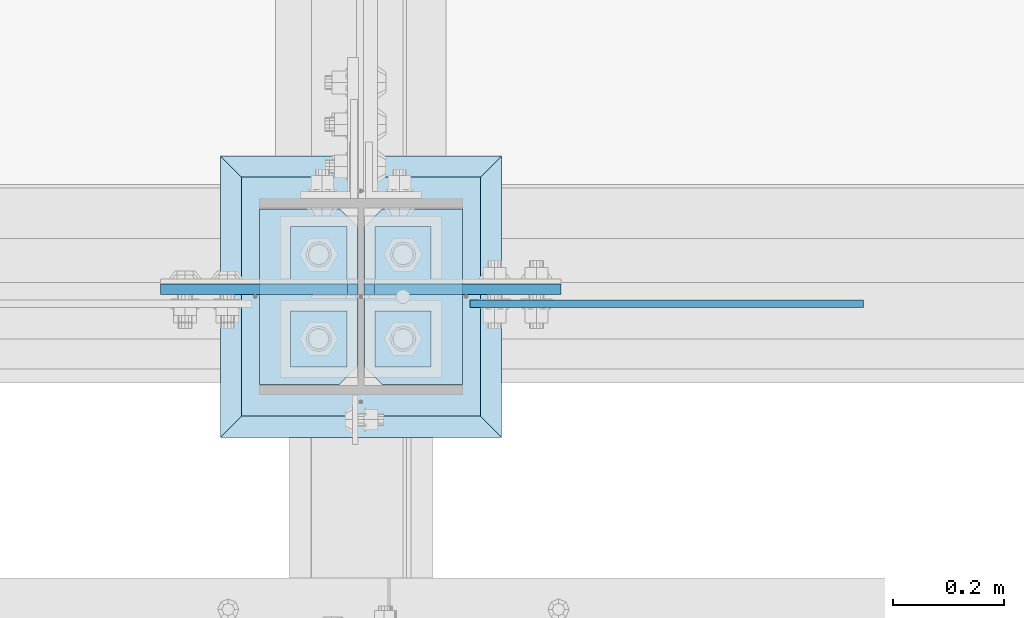
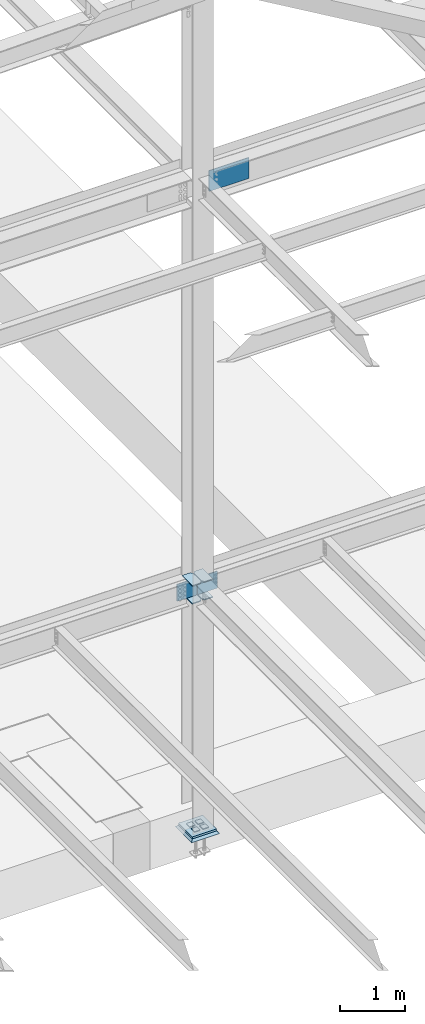
# One storey, part 3190 of 3843: 13 plates, 4 elements without a shape of their own.
"""IFC2X3 building model written with IfcOpenShell, lengths in millimetres."""

from ifc_helpers import new_model, si_unit, frame, origin_with_axes, place, context, subcontext, project, spatial, faceted_brep, material, type_object, element, aggregate, save


model = new_model("IFC2X3")

# Units and contexts
model_context = context("Model", 3, precision=1e-05, world=origin_with_axes())
body_context = subcontext(model_context, "Body", "Model", "MODEL_VIEW")
ifc_project = project(units=[si_unit("LENGTHUNIT", "METRE", prefix="MILLI"), si_unit("AREAUNIT", "SQUARE_METRE"), si_unit("VOLUMEUNIT", "CUBIC_METRE"), si_unit("MASSUNIT", "GRAM", prefix="KILO"), si_unit("TIMEUNIT", "SECOND"), si_unit("PLANEANGLEUNIT", "RADIAN"), si_unit("SOLIDANGLEUNIT", "STERADIAN"), si_unit("THERMODYNAMICTEMPERATUREUNIT", "DEGREE_CELSIUS"), si_unit("LUMINOUSINTENSITYUNIT", "LUMEN")], contexts=[model_context])

# Site, building, storey
site_placement = place(None, origin_with_axes())
site = spatial("IfcSite", under=ifc_project, at=site_placement, CompositionType="ELEMENT")
building_placement = place(site_placement, origin_with_axes())
building = spatial("IfcBuilding", under=site, at=building_placement, Name="Undefined", CompositionType="ELEMENT")
storey_placement = place(building_placement, origin_with_axes())
storey = spatial("IfcBuildingStorey", under=building, at=storey_placement, Name="Undefined", CompositionType="ELEMENT", Elevation=0.0)

# Assembly, plates
assembly_1_placement = place(storey_placement, origin_with_axes())
assembly_1 = element("IfcElementAssembly", 1, at=assembly_1_placement, inside=storey, Name="COLUMN", AssemblyPlace="NOTDEFINED", PredefinedType="RIGID_FRAME")
ifc_material_1 = material(Name="STEEL/A572-50")
plate_type_1 = type_object("IfcPlateType", PredefinedType="NOTDEFINED")
plate_1_placement = place(assembly_1_placement, frame((70439.75625, 25457.15, 34451.925), z_axis=(0.0, 1.0, 0.0), x_axis=(-1.0, 0.0, 0.0)))
plate_1 = element("IfcPlate", 2, at=plate_1_placement, type_object=plate_type_1, material=ifc_material_1, Name="PLATE", context=body_context, shape_type="Brep", body=[
    faceted_brep([(0.0, -9.52500000000146, 0.0), (0.0, -9.52500000000146, 317.5), (0.0, 9.52500000000146, 317.5), (0.0, 9.52500000000146, 0.0), (144.462501525879, -9.52500000000146, 317.5), (144.462501525879, 9.52500000000146, 317.5), (177.800003051758, -9.52500000000146, 284.162498474121), (177.800003051758, 9.52500000000146, 284.162498474121), (177.800003051758, -9.52500000000146, 33.3375015258789), (177.800003051758, 9.52500000000146, 33.3375015258789), (144.462501525879, -9.52500000000146, 0.0), (144.462501525879, 9.52500000000146, 0.0)], [[[0, 1, 2, 3]], [[1, 4, 5, 2]], [[4, 6, 7, 5]], [[6, 8, 9, 7]], [[8, 10, 11, 9]], [[10, 0, 3, 11]], [[5, 7, 9, 11, 3, 2]], [[10, 8, 6, 4, 1, 0]]]),
])
plate_2_placement = place(assembly_1_placement, frame((70439.75625, 25457.15, 34788.475), z_axis=(0.0, 1.0, 0.0), x_axis=(-1.0, 0.0, 0.0)))
plate_2 = element("IfcPlate", 3, at=plate_2_placement, type_object=plate_type_1, material=ifc_material_1, Name="PLATE", context=body_context, shape_type="Brep", body=[
    faceted_brep([(0.0, -9.52500000000146, 0.0), (0.0, -9.52500000000146, 317.5), (0.0, 9.52500000000146, 317.5), (0.0, 9.52500000000146, 0.0), (144.462501525879, -9.52500000000146, 317.5), (144.462501525879, 9.52500000000146, 317.5), (177.800003051758, -9.52500000000146, 284.162498474121), (177.800003051758, 9.52500000000146, 284.162498474121), (177.800003051758, -9.52500000000146, 33.3375015258789), (177.800003051758, 9.52500000000146, 33.3375015258789), (144.462501525879, -9.52500000000146, 0.0), (144.462501525879, 9.52500000000146, 0.0)], [[[0, 1, 2, 3]], [[1, 4, 5, 2]], [[4, 6, 7, 5]], [[6, 8, 9, 7]], [[8, 10, 11, 9]], [[10, 0, 3, 11]], [[5, 7, 9, 11, 3, 2]], [[10, 8, 6, 4, 1, 0]]]),
])
plate_3_placement = place(assembly_1_placement, frame((70073.04375, 25774.65, 34451.925), z_axis=(0.0, -1.0, 0.0), x_axis=(1.0, 0.0, 0.0)))
plate_3 = element("IfcPlate", 4, at=plate_3_placement, type_object=plate_type_1, material=ifc_material_1, Name="PLATE", context=body_context, shape_type="Brep", body=[
    faceted_brep([(0.0, -9.52500000000146, 0.0), (0.0, -9.52500000000146, 317.5), (0.0, 9.52500000000146, 317.5), (0.0, 9.52500000000146, 0.0), (144.462501525879, -9.52500000000146, 317.5), (144.462501525879, 9.52500000000146, 317.5), (177.800003051758, -9.52500000000146, 284.162498474121), (177.800003051758, 9.52500000000146, 284.162498474121), (177.800003051758, -9.52500000000146, 33.3375015258789), (177.800003051758, 9.52500000000146, 33.3375015258789), (144.462501525879, -9.52500000000146, 0.0), (144.462501525879, 9.52500000000146, 0.0)], [[[0, 1, 2, 3]], [[1, 4, 5, 2]], [[4, 6, 7, 5]], [[6, 8, 9, 7]], [[8, 10, 11, 9]], [[10, 0, 3, 11]], [[5, 7, 9, 11, 3, 2]], [[10, 8, 6, 4, 1, 0]]]),
])
plate_4_placement = place(assembly_1_placement, frame((70073.04375, 25774.65, 34788.475), z_axis=(0.0, -1.0, 0.0), x_axis=(1.0, 0.0, 0.0)))
plate_4 = element("IfcPlate", 5, at=plate_4_placement, type_object=plate_type_1, material=ifc_material_1, Name="PLATE", context=body_context, shape_type="Brep", body=[
    faceted_brep([(0.0, -9.52500000000146, 0.0), (0.0, -9.52500000000146, 317.5), (0.0, 9.52500000000146, 317.5), (0.0, 9.52500000000146, 0.0), (144.462501525879, -9.52500000000146, 317.5), (144.462501525879, 9.52500000000146, 317.5), (177.800003051758, -9.52500000000146, 284.162498474121), (177.800003051758, 9.52500000000146, 284.162498474121), (177.800003051758, -9.52500000000146, 33.3375015258789), (177.800003051758, 9.52500000000146, 33.3375015258789), (144.462501525879, -9.52500000000146, 0.0), (144.462501525879, 9.52500000000146, 0.0)], [[[0, 1, 2, 3]], [[1, 4, 5, 2]], [[4, 6, 7, 5]], [[6, 8, 9, 7]], [[8, 10, 11, 9]], [[10, 0, 3, 11]], [[5, 7, 9, 11, 3, 2]], [[10, 8, 6, 4, 1, 0]]]),
])
plate_type_2 = type_object("IfcPlateType", PredefinedType="NOTDEFINED")
plate_5_placement = place(assembly_1_placement, frame((70261.95625, 25629.39375, 34480.5000026613), z_axis=(0.707106781186548, 0.0, 0.707106781186548), x_axis=(0.707106781186548, 0.0, -0.707106781186548)))
plate_5 = element("IfcPlate", 6, at=plate_5_placement, type_object=plate_type_2, material=ifc_material_1, Name="PLATE", context=body_context, shape_type="Brep", body=[
    faceted_brep([(0.0, -9.52500000000146, 0.0), (-197.565634662966, -9.52499999999964, 197.565634662184), (-197.565634662966, 9.52499999999964, 197.565634662184), (0.0, 9.52500000000146, 0.0), (-197.565634662868, -9.52499999999964, 224.506403025414), (-197.565634662868, 9.52499999999964, 224.506403025414), (40.9724185538689, -9.52500000000146, 463.044456243078), (40.9724185538689, 9.52500000000146, 463.044456243078), (265.478821579974, -9.52500000000146, 238.538053217882), (265.478821579974, 9.52500000000146, 238.538053217882), (26.9407683632344, -9.52499999999964, 2.03726813197136e-10), (26.9407683632344, 9.52499999999964, 2.03726813197136e-10)], [[[0, 1, 2, 3]], [[1, 4, 5, 2]], [[4, 6, 7, 5]], [[6, 8, 9, 7]], [[8, 10, 11, 9]], [[10, 0, 3, 11]], [[5, 7, 9, 11, 3, 2]], [[10, 8, 6, 4, 1, 0]]]),
])
plate_6_placement = place(assembly_1_placement, frame((70250.84375, 25629.39375, 34480.5000026613), z_axis=(-0.707106781186548, 0.0, 0.707106781186548), x_axis=(-0.707106781186548, 0.0, -0.707106781186548)))
plate_6 = element("IfcPlate", 7, at=plate_6_placement, type_object=plate_type_2, material=ifc_material_1, Name="PLATE", context=body_context, shape_type="Brep", body=[
    faceted_brep([(0.0, -9.52500000000146, 0.0), (-197.565634662966, -9.52499999999964, 197.565634662184), (-197.565634662966, 9.52499999999964, 197.565634662184), (0.0, 9.52500000000146, 0.0), (-197.565634662868, -9.52499999999964, 224.506403025414), (-197.565634662868, 9.52499999999964, 224.506403025414), (40.9724185538689, -9.52500000000146, 463.044456243078), (40.9724185538689, 9.52500000000146, 463.044456243078), (265.478821579974, -9.52500000000146, 238.538053217882), (265.478821579974, 9.52500000000146, 238.538053217882), (26.9407683632344, -9.52499999999964, 2.03726813197136e-10), (26.9407683632344, 9.52499999999964, 2.03726813197136e-10)], [[[0, 1, 2, 3]], [[1, 4, 5, 2]], [[4, 6, 7, 5]], [[6, 8, 9, 7]], [[8, 10, 11, 9]], [[10, 0, 3, 11]], [[5, 7, 9, 11, 3, 2]], [[10, 8, 6, 4, 1, 0]]]),
])

assembly_2_placement = place(storey_placement, origin_with_axes())
assembly_2 = element("IfcElementAssembly", 8, at=assembly_2_placement, inside=storey, Name="TEMPLATE", AssemblyPlace="NOTDEFINED", PredefinedType="RIGID_FRAME")
plate_type_3 = type_object("IfcPlateType", PredefinedType="NOTDEFINED")
plate_7_placement = place(assembly_2_placement, frame((70231.0, 25590.5, 30105.35), z_axis=(-1.0, 0.0, 0.0), x_axis=(0.0, -1.0, 0.0)))
plate_7 = element("IfcPlate", 9, at=plate_7_placement, type_object=plate_type_3, material=ifc_material_1, Name="Washer Plate", context=body_context, shape_type="Brep", body=[
    faceted_brep([(0.0, -6.3499999046162, 0.0), (-1.67347025126219e-10, -6.35000000000582, 101.600000000151), (-1.67347025126219e-10, 6.35000000000582, 101.600000000151), (7.27595761418343e-12, 6.3499999046162, 0.0), (101.599998474121, -6.34999999999854, 101.599998474121), (101.599998474121, 6.34999999999854, 101.599998474121), (101.6, -6.34999999999854, 0.0), (101.6, 6.34999999999854, 0.0)], [[[0, 1, 2, 3]], [[1, 4, 5, 2]], [[4, 6, 7, 5]], [[6, 0, 3, 7]], [[5, 7, 3, 2]], [[6, 4, 1, 0]]]),
])
plate_8_placement = place(assembly_2_placement, frame((70383.4, 25590.5, 30105.35), z_axis=(-1.0, 0.0, 0.0), x_axis=(0.0, -1.0, 0.0)))
plate_8 = element("IfcPlate", 10, at=plate_8_placement, type_object=plate_type_3, material=ifc_material_1, Name="Washer Plate", context=body_context, shape_type="Brep", body=[
    faceted_brep([(0.0, -6.3499999046162, 0.0), (-1.67347025126219e-10, -6.35000000000582, 101.600000000151), (-1.67347025126219e-10, 6.35000000000582, 101.600000000151), (7.27595761418343e-12, 6.3499999046162, 0.0), (101.599998474121, -6.34999999999854, 101.599998474121), (101.599998474121, 6.34999999999854, 101.599998474121), (101.6, -6.34999999999854, 0.0), (101.6, 6.34999999999854, 0.0)], [[[0, 1, 2, 3]], [[1, 4, 5, 2]], [[4, 6, 7, 5]], [[6, 0, 3, 7]], [[5, 7, 3, 2]], [[6, 4, 1, 0]]]),
])
plate_9_placement = place(assembly_2_placement, frame((70231.0, 25742.9, 30105.35), z_axis=(-1.0, 0.0, 0.0), x_axis=(0.0, -1.0, 0.0)))
plate_9 = element("IfcPlate", 11, at=plate_9_placement, type_object=plate_type_3, material=ifc_material_1, Name="Washer Plate", context=body_context, shape_type="Brep", body=[
    faceted_brep([(0.0, -6.3499999046162, 0.0), (-1.67347025126219e-10, -6.35000000000582, 101.600000000151), (-1.67347025126219e-10, 6.35000000000582, 101.600000000151), (7.27595761418343e-12, 6.3499999046162, 0.0), (101.599998474121, -6.34999999999854, 101.599998474121), (101.599998474121, 6.34999999999854, 101.599998474121), (101.6, -6.34999999999854, 0.0), (101.6, 6.34999999999854, 0.0)], [[[0, 1, 2, 3]], [[1, 4, 5, 2]], [[4, 6, 7, 5]], [[6, 0, 3, 7]], [[5, 7, 3, 2]], [[6, 4, 1, 0]]]),
])
plate_10_placement = place(assembly_2_placement, frame((70383.4, 25742.9, 30105.35), z_axis=(-1.0, 0.0, 0.0), x_axis=(0.0, -1.0, 0.0)))
plate_10 = element("IfcPlate", 12, at=plate_10_placement, type_object=plate_type_3, material=ifc_material_1, Name="Washer Plate", context=body_context, shape_type="Brep", body=[
    faceted_brep([(0.0, -6.3499999046162, 0.0), (-1.67347025126219e-10, -6.35000000000582, 101.600000000151), (-1.67347025126219e-10, 6.35000000000582, 101.600000000151), (7.27595761418343e-12, 6.3499999046162, 0.0), (101.599998474121, -6.34999999999854, 101.599998474121), (101.599998474121, 6.34999999999854, 101.599998474121), (101.6, -6.34999999999854, 0.0), (101.6, 6.34999999999854, 0.0)], [[[0, 1, 2, 3]], [[1, 4, 5, 2]], [[4, 6, 7, 5]], [[6, 0, 3, 7]], [[5, 7, 3, 2]], [[6, 4, 1, 0]]]),
])
aggregate(assembly_2, [plate_7, plate_8, plate_9, plate_10])

# Assembly, plate
assembly_3_placement = place(storey_placement, origin_with_axes())
assembly_3 = element("IfcElementAssembly", 13, at=assembly_3_placement, inside=storey, Name="BEAM", AssemblyPlace="NOTDEFINED", PredefinedType="RIGID_FRAME")
plate_type_4 = type_object("IfcPlateType", PredefinedType="NOTDEFINED")
plate_11_placement = place(assembly_3_placement, frame((70453.25, 25603.2000000001, 42017.949987793), z_axis=(0.0, 0.0, 1.0), x_axis=(1.0, 0.0, 0.0)))
plate_11 = element("IfcPlate", 14, at=plate_11_placement, type_object=plate_type_4, material=ifc_material_1, Name="PLATE", context=body_context, shape_type="Brep", body=[
    faceted_brep([(0.0, -6.3499999046162, 0.0), (0.0, -6.34999999999854, 393.700012207031), (0.0, 6.34999999999854, 393.700012207031), (7.27595761418343e-12, 6.3499999046162, 0.0), (711.199999999968, -6.35000000000582, 393.700012207031), (711.200000000012, 6.34999999999854, 393.700000000004), (711.199999999968, -6.35000000000582, 0.0), (711.199999999997, 6.34999999999854, 0.0)], [[[0, 1, 2, 3]], [[1, 4, 5, 2]], [[4, 6, 7, 5]], [[6, 0, 3, 7]], [[7, 3, 2, 5]], [[6, 4, 1, 0]]]),
])
aggregate(assembly_3, [plate_11])

# Plate
plate_type_5 = type_object("IfcPlateType", PredefinedType="NOTDEFINED")
plate_12_placement = place(assembly_1_placement, frame((70040.5, 25831.8, 30079.95), z_axis=(1.0, 0.0, 0.0), x_axis=(0.0, -1.0, 0.0)))
plate_12 = element("IfcPlate", 15, at=plate_12_placement, type_object=plate_type_5, material=ifc_material_1, Name="PLATE", context=body_context, shape_type="Brep", body=[
    faceted_brep([(0.0, -19.0500000000029, 0.0), (0.0, -19.0499999999993, 431.799987792969), (0.0, 19.0499999999993, 431.799987792969), (0.0, 19.0500000000029, 0.0), (431.799987792969, -19.0499999999993, 431.799987792969), (431.799987792969, 19.0499999999993, 431.799987792969), (431.799957275391, -19.0499999999993, 0.0), (431.799957275391, 19.0499999999993, 0.0)], [[[0, 1, 2, 3]], [[1, 4, 5, 2]], [[4, 6, 7, 5]], [[6, 0, 3, 7]], [[5, 7, 3, 2]], [[6, 4, 1, 0]]]),
])

aggregate(assembly_1, [plate_1, plate_2, plate_5, plate_3, plate_4, plate_6, plate_12])

# Assembly, plate
assembly_4_placement = place(storey_placement, origin_with_axes())
assembly_4 = element("IfcElementAssembly", 16, at=assembly_4_placement, inside=storey, Name="GROUT", AssemblyPlace="NOTDEFINED", PredefinedType="REINFORCEMENT_UNIT")
ifc_material_2 = material(Name="CONCRETE/Concrete_Undefined")
plate_type_6 = type_object("IfcPlateType", PredefinedType="NOTDEFINED")
plate_13_placement = place(assembly_4_placement, frame((70002.4, 25869.9, 30041.85), z_axis=(1.0, 0.0, 0.0), x_axis=(0.0, -1.0, 0.0)))
plate_13 = element("IfcPlate", 17, at=plate_13_placement, type_object=plate_type_6, material=ifc_material_2, Name="GROUT", context=body_context, shape_type="Brep", body=[
    faceted_brep([(38.1000000007043, -19.0499999997883, 469.899999999314), (0.0, 19.0499999999993, 508.0), (0.0, 19.0500000000029, 0.0), (38.1000000006916, -19.0499999999811, 38.1000000006607), (469.899999999325, -19.0499999998174, 38.1000000006607), (508.0, 19.0499999999993, 0.0), (508.0, 19.0499999999993, 508.0), (469.899999999325, -19.0499999999847, 469.899999999314)], [[[0, 1, 2, 3]], [[4, 5, 6, 7]], [[4, 7, 0, 3]], [[5, 4, 3, 2]], [[6, 5, 2, 1]], [[7, 6, 1, 0]]]),
])
aggregate(assembly_4, [plate_13])

save(model, "model.ifc")
